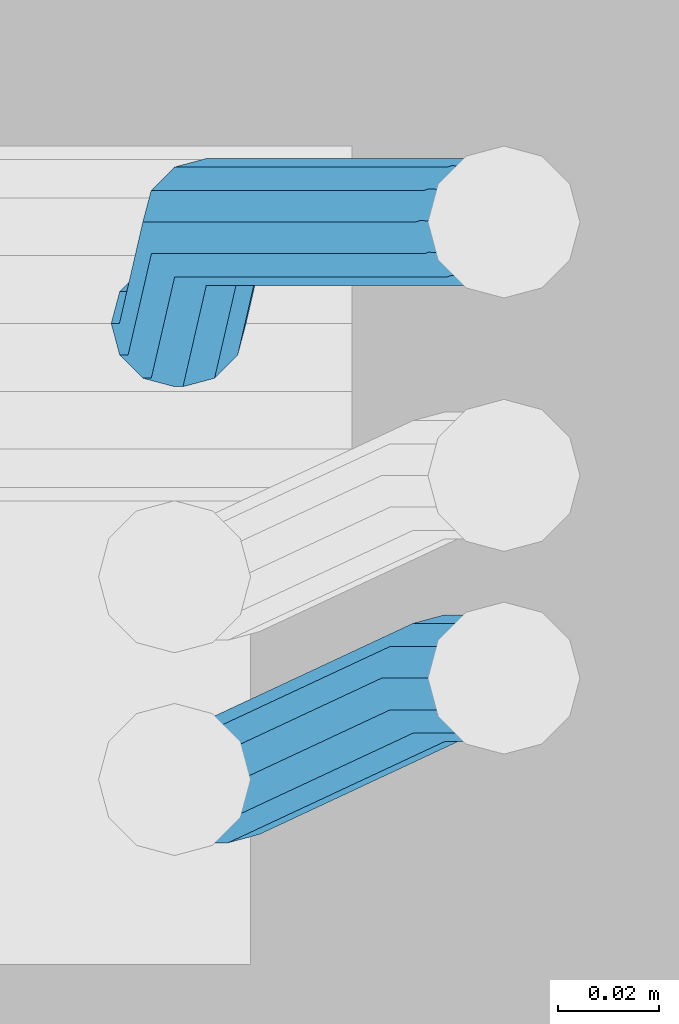
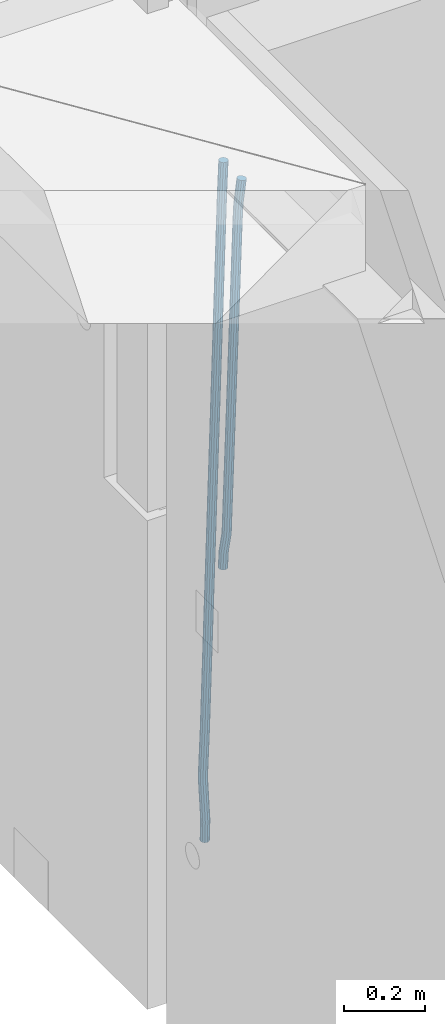
# One storey, part 122 of 350: 2 beams, 1 element without a shape of its own.
"""IFC2X3 building model written with IfcOpenShell, lengths in millimetres."""

from ifc_helpers import new_model, si_unit, frame, origin_with_axes, place, context, subcontext, project, spatial, faceted_brep, material, type_object, element, aggregate, save


model = new_model("IFC2X3")

# Units and contexts
model_context = context("Model", 3, precision=1e-05, world=origin_with_axes())
body_context = subcontext(model_context, "Body", "Model", "MODEL_VIEW")
ifc_project = project(units=[si_unit("LENGTHUNIT", "METRE", prefix="MILLI"), si_unit("AREAUNIT", "SQUARE_METRE"), si_unit("VOLUMEUNIT", "CUBIC_METRE"), si_unit("MASSUNIT", "GRAM", prefix="KILO"), si_unit("TIMEUNIT", "SECOND"), si_unit("PLANEANGLEUNIT", "RADIAN"), si_unit("SOLIDANGLEUNIT", "STERADIAN"), si_unit("THERMODYNAMICTEMPERATUREUNIT", "DEGREE_CELSIUS"), si_unit("LUMINOUSINTENSITYUNIT", "LUMEN")], contexts=[model_context])

# Site, building, storey
site_placement = place(None, origin_with_axes())
site = spatial("IfcSite", under=ifc_project, at=site_placement, CompositionType="ELEMENT")
building_placement = place(site_placement, origin_with_axes())
building = spatial("IfcBuilding", under=site, at=building_placement, CompositionType="ELEMENT")
storey_placement = place(building_placement, origin_with_axes())
storey = spatial("IfcBuildingStorey", under=building, at=storey_placement, Name="2", CompositionType="ELEMENT", Elevation=0.0)

# Assembly, beams
assembly_placement = place(storey_placement, origin_with_axes())
assembly = element("IfcElementAssembly", 1, at=assembly_placement, inside=storey, AssemblyPlace="NOTDEFINED", PredefinedType="REINFORCEMENT_UNIT")
ifc_material = material()
beam_type = type_object("IfcBeamType", Name="D25", PredefinedType="NOTDEFINED")
beam_1_placement = place(assembly_placement, frame((17644.9989431251, 20116.4982803956, 86267.5035525011), z_axis=(0.0, 1.0, 0.0), x_axis=(0.0467115440025518, 0.0, 0.998908420055061)))
beam_1 = element("IfcBeam", 2, at=beam_1_placement, type_object=beam_type, material=ifc_material, Name="JM25", ObjectType="D25", context=body_context, shape_type="Brep", body=[
    faceted_brep([(-7.41420080885291e-08, -12.5, -3.63797880709171e-12), (-6.42030499875546e-08, -10.8253175473074, -6.25000000000364), (48.7743672639481, -10.8253174221936, -6.25), (48.7743672682554, -12.4999998748863, 0.0), (-3.70782800018787e-08, -6.25000000000364, -10.8253175473074), (48.7743672522192, -6.24999987488263, -10.8253175473037), (-1.45519152283669e-11, -3.63797880709171e-12, -12.5), (48.7743672361976, 1.25113729154691e-07, -12.5), (3.70637280866504e-08, 6.25, -10.8253175473074), (48.7743672201614, 6.25000012511737, -10.8253175473037), (6.42030499875546e-08, 10.8253175473001, -6.25000000000364), (48.774367208418, 10.8253176724174, -6.25), (7.41420080885291e-08, 12.4999999999927, 0.0), (48.7743672041252, 12.5000001251174, 0.0), (6.42176019027829e-08, 10.8253175473001, 6.24999999999636), (48.774367208418, 10.8253176724174, 6.25), (3.70928319171071e-08, 6.24999999999636, 10.8253175473037), (48.7743672201614, 6.25000012511737, 10.8253175473037), (1.45519152283669e-11, -3.63797880709171e-12, 12.4999999999964), (48.7743672361976, 1.25113729154691e-07, 12.5), (-3.7049176171422e-08, -6.25000000000364, 10.8253175473001), (48.7743672522192, -6.24999987488263, 10.8253175473037), (-6.41884980723262e-08, -10.8253175473074, 6.25), (48.7743672639481, -10.8253174221936, 6.25), (50.6284132863948, -10.8253174174351, -6.25), (50.7256294211547, -12.4999998698804, 0.0), (50.362813866901, -6.2499998708081, -10.8253175473037), (49.9999983126327, 1.28262399812229e-07, -12.5), (49.6371827583935, 6.25000012732926, -10.8253175473037), (49.3715833388851, 10.8253176739527, -6.25), (49.2743672041252, 12.5000001264016, 0.0), (49.3715833388851, 10.8253176739527, 6.25), (49.6371827583935, 6.25000012732926, 10.8253175473037), (49.9999983126327, 1.28262399812229e-07, 12.5), (50.362813866901, -6.2499998708081, 10.8253175473037), (50.6284132863948, -10.8253174174351, 6.25), (52.4700055286376, -10.6107838149001, -6.25), (52.6637847850943, -12.2742172873113, 0.0), (51.9405907545442, -6.0661990532717, -10.8253175473037), (51.2173967239651, 0.141819180764287, -12.5), (50.494202693415, 6.34983741480755, -10.8253175473037), (49.9647879192926, 10.8944221764359, -6.25), (49.7710086628358, 12.5578556488472, 0.0), (49.9647879192926, 10.8944221764359, 6.25), (50.494202693415, 6.34983741480755, 10.8253175473037), (51.2173967239651, 0.141819180764287, 12.5), (51.9405907545442, -6.0661990532717, 10.8253175473037), (52.4700055286376, -10.6107838149037, 6.25), (100.1682419055, -5.05424733003747, -6.25), (100.362021161956, -6.71768080244692, 0.0), (99.6388271314063, -0.509662568409112, -10.8253175473037), (98.9156331008271, 5.69835566563052, -12.5), (98.192439070277, 11.9063738996665, -10.8253175473037), (97.6630242961546, 16.4509586612985, -6.25), (97.4692450396979, 18.1143921337098, 0.0), (97.6630242961546, 16.4509586612985, 6.25), (98.192439070277, 11.9063738996665, 10.8253175473037), (98.9156331008271, 5.69835566563052, 12.5), (99.6388271314063, -0.509662568409112, 10.8253175473037), (100.1682419055, -5.05424733003747, 6.25), (100.829389846811, -4.97722786481609, -6.25), (100.858662620667, -6.65982528000313, 0.0), (100.613505361369, -0.39611884945225, -10.8253175473037), (100.268855237926, 5.8559973049887, -12.5), (99.8877881987282, 12.1038711239344, -10.8253175473037), (99.5724108491268, 16.6733898631865, -6.25), (99.4072282953421, 18.3401546667665, 0.0), (99.4365010692127, 16.6575572515831, 6.25), (99.6523855546402, 12.0764482362174, 10.8253175473037), (99.9970356780832, 5.82433208178009, 12.5), (100.37810271731, -0.423541737165579, 10.8253175473037), (100.693480066882, -4.99306047642312, 6.25), (101.494850382805, -4.9772278650471, -6.23547852116099), (101.358543616545, -6.65982528017412, 0.0109082521194068), (101.594541309358, -0.396118849792401, -10.8039096771354), (101.63090429295, 5.85599730451395, -12.4702777768798), (101.594195901474, 12.1038711233377, -10.7880808337759), (101.49425211882, 16.6733898625134, -6.2080621602363), (101.357852800793, 18.340154666088, 0.0425659388420172), (101.221546034547, 16.6575572509591, 6.28895271212241), (101.121855107995, 12.0764482357044, 10.8573838680968), (101.085492124403, 5.82433208139992, 12.5237519678412), (101.122200515863, -0.423541737425694, 10.8415550247373), (101.222144298532, -4.99306047660866, 6.26153635119772), (1016.15234243186, -4.97722818425427, 13.7239010304511), (1016.01603566563, -6.65982559938311, 19.9702878037351), (1016.25203335841, -0.396119168995938, 9.15546987447669), (1016.28839634202, 5.85599698530859, 7.48910177473226), (1016.25168795056, 12.1038708041378, 9.17129871783618), (1016.15174416787, 16.6733895433135, 13.7513173913758), (1016.01534484986, 18.3401543468826, 20.0019454904541), (1015.8790380836, 16.6575569317556, 26.2483322637381), (1015.77934715705, 12.0764479165045, 30.8167634197125), (1015.74298417347, 5.82433176219456, 32.4831315194569), (1015.77969256493, -0.423542056632868, 30.8009345763494), (1015.8796363476, -4.99306079580856, 26.2209159028134), (1016.72024271244, -4.97722818445254, 13.7362935788587), (1016.65208128402, -6.65982559960139, 19.984167399125), (1016.77009392806, -0.396119169179656, 9.16677483576495), (1016.7882773379, 5.85599698513579, 7.50001002685531), (1016.76992071191, 12.1038708039559, 9.18260743664359), (1016.71994269331, 16.6733895431171, 13.7637164479929), (1016.65173485172, 18.3401543466607, 20.015832600875), (1016.58357342328, 16.65755693151, 26.2637064211413), (1016.53372220766, 12.0764479162353, 30.833225164235), (1016.51553879784, 5.82433176192717, 32.4999899731447), (1016.53389542381, -0.423542056894803, 30.8173925633564), (1016.58387344243, -4.99306079605594, 26.2362835520071), (1017.28827819017, -4.97722813975997, 13.7362935788587), (1017.28827832255, -6.6598255495519, 19.984167399125), (1017.28827782976, -0.396119128414284, 9.16677483576495), (1017.28827733788, 5.85599702447144, 7.50001002685531), (1017.28827684635, 12.103870844734, 9.18260743664359), (1017.28827648686, 16.6733895878278, 13.7637164479929), (1017.28827635571, 18.3401543967448, 20.015832600875), (1017.28827648809, 16.657556986951, 26.2637064211413), (1017.2882768485, 12.0764479756035, 30.833225164235), (1017.28827734038, 5.8243318227178, 32.4999899731447), (1017.28827783192, -0.423541997544817, 30.8173925633564), (1017.28827819142, -4.99306074063679, 26.2362835520071), (1065.6667756622, -4.97722433367016, 13.7362935788587), (1065.66677579457, -6.65982174345845, 19.984167399125), (1065.6667753018, -0.3961153223172, 9.16677483576495), (1065.66677480991, 5.85600083056488, 7.50001002685531), (1065.66677431838, 12.1038746508275, 9.18260743664359), (1065.66677395887, 16.6733933939249, 13.7637164479929), (1065.66677382775, 18.3401582028346, 20.015832600875), (1065.66677396011, 16.6575607930445, 26.2637064211413), (1065.66677432053, 12.0764517816933, 30.833225164235), (1065.6667748124, 5.82433562881488, 32.4999899731447), (1065.66677530395, -0.423538191451371, 30.8173925633564), (1065.66677566344, -4.99305693454517, 26.2362835520071), (1067.07165110651, -4.97722422314291, 13.7362935788587), (1067.13694763639, -6.65982162779255, 19.984167399125), (1066.89387208481, -0.396115225779795, 9.16677483576495), (1066.6512463166, 5.85600090801745, 7.50001002685531), (1066.40878518049, 12.1038747092061, 9.18260743664359), (1066.23145594214, 16.6733934383519, 13.7637164479929), (1066.16677382775, 18.340158242172, 20.015832600875), (1066.23207035761, 16.6575608375188, 26.2637064211413), (1066.40984937931, 12.0764518401556, 30.833225164235), (1066.65247514757, 5.82433570636204, 32.4999899731447), (1066.89493628364, -0.423538094826654, 30.8173925633564), (1067.07226552199, -4.99305682397062, 26.2362835520071), (1068.47230333716, -4.86837412698696, 13.736334784764), (1068.60269804588, -6.54588751704068, 19.9842150143704), (1068.11728165975, -0.301059828409052, 9.16679859123906), (1067.63276078545, 5.93224720081525, 7.50000996663584), (1067.14856769117, 12.161337376032, 9.18258357686864), (1066.79444152558, 16.7171310152116, 13.7636751818718), (1066.66527010873, 18.3789068918468, 20.0157849856296), (1066.79566481744, 16.7013935018003, 26.263665215236), (1067.15068649485, 12.134079203217, 30.8332014087609), (1067.63520736917, 5.90077217399266, 32.4999900333642), (1068.11940046342, -0.328318001224034, 30.8174164231314), (1068.47352662902, -4.88411164040008, 26.2363248181282), (1142.62319484423, 0.89544508106701, 13.736334784764), (1142.75358955294, -0.782068308983071, 19.9842150143704), (1142.26817316683, 5.4627593796431, 9.16679859123906), (1141.78365229251, 11.6960664088729, 7.50000996663584), (1141.29945919824, 17.9251565840896, 9.18258357686864), (1140.94533303265, 22.4809502232638, 13.7636751818718), (1140.81616161579, 24.1427260999008, 20.0157849856296), (1140.94655632452, 22.4652127098525, 26.263665215236), (1141.30157800192, 17.8978984112746, 30.8332014087609), (1141.78609887623, 11.6645913820466, 32.4999900333642), (1142.27029197049, 5.43550120682994, 30.8174164231314), (1142.6244181361, 0.879707567652076, 26.2363248181282)], [[[0, 1, 2, 3]], [[1, 4, 5, 2]], [[4, 6, 7, 5]], [[6, 8, 9, 7]], [[8, 10, 11, 9]], [[10, 12, 13, 11]], [[12, 14, 15, 13]], [[14, 16, 17, 15]], [[16, 18, 19, 17]], [[18, 20, 21, 19]], [[20, 22, 23, 21]], [[22, 0, 3, 23]], [[22, 20, 18, 16, 14, 12, 10, 8, 6, 4, 1, 0]], [[3, 2, 24, 25]], [[2, 5, 26, 24]], [[5, 7, 27, 26]], [[7, 9, 28, 27]], [[9, 11, 29, 28]], [[11, 13, 30, 29]], [[13, 15, 31, 30]], [[15, 17, 32, 31]], [[17, 19, 33, 32]], [[19, 21, 34, 33]], [[21, 23, 35, 34]], [[23, 3, 25, 35]], [[25, 24, 36, 37]], [[24, 26, 38, 36]], [[26, 27, 39, 38]], [[27, 28, 40, 39]], [[28, 29, 41, 40]], [[29, 30, 42, 41]], [[30, 31, 43, 42]], [[31, 32, 44, 43]], [[32, 33, 45, 44]], [[33, 34, 46, 45]], [[34, 35, 47, 46]], [[35, 25, 37, 47]], [[37, 36, 48, 49]], [[36, 38, 50, 48]], [[38, 39, 51, 50]], [[39, 40, 52, 51]], [[40, 41, 53, 52]], [[41, 42, 54, 53]], [[42, 43, 55, 54]], [[43, 44, 56, 55]], [[44, 45, 57, 56]], [[45, 46, 58, 57]], [[46, 47, 59, 58]], [[47, 37, 49, 59]], [[49, 48, 60, 61]], [[48, 50, 62, 60]], [[50, 51, 63, 62]], [[51, 52, 64, 63]], [[52, 53, 65, 64]], [[53, 54, 66, 65]], [[54, 55, 67, 66]], [[55, 56, 68, 67]], [[56, 57, 69, 68]], [[57, 58, 70, 69]], [[58, 59, 71, 70]], [[59, 49, 61, 71]], [[61, 60, 72, 73]], [[60, 62, 74, 72]], [[62, 63, 75, 74]], [[63, 64, 76, 75]], [[64, 65, 77, 76]], [[65, 66, 78, 77]], [[66, 67, 79, 78]], [[67, 68, 80, 79]], [[68, 69, 81, 80]], [[69, 70, 82, 81]], [[70, 71, 83, 82]], [[71, 61, 73, 83]], [[73, 72, 84, 85]], [[72, 74, 86, 84]], [[74, 75, 87, 86]], [[75, 76, 88, 87]], [[76, 77, 89, 88]], [[77, 78, 90, 89]], [[78, 79, 91, 90]], [[79, 80, 92, 91]], [[80, 81, 93, 92]], [[81, 82, 94, 93]], [[82, 83, 95, 94]], [[83, 73, 85, 95]], [[85, 84, 96, 97]], [[84, 86, 98, 96]], [[86, 87, 99, 98]], [[87, 88, 100, 99]], [[88, 89, 101, 100]], [[89, 90, 102, 101]], [[90, 91, 103, 102]], [[91, 92, 104, 103]], [[92, 93, 105, 104]], [[93, 94, 106, 105]], [[94, 95, 107, 106]], [[95, 85, 97, 107]], [[97, 96, 108, 109]], [[96, 98, 110, 108]], [[98, 99, 111, 110]], [[99, 100, 112, 111]], [[100, 101, 113, 112]], [[101, 102, 114, 113]], [[102, 103, 115, 114]], [[103, 104, 116, 115]], [[104, 105, 117, 116]], [[105, 106, 118, 117]], [[106, 107, 119, 118]], [[107, 97, 109, 119]], [[109, 108, 120, 121]], [[108, 110, 122, 120]], [[110, 111, 123, 122]], [[111, 112, 124, 123]], [[112, 113, 125, 124]], [[113, 114, 126, 125]], [[114, 115, 127, 126]], [[115, 116, 128, 127]], [[116, 117, 129, 128]], [[117, 118, 130, 129]], [[118, 119, 131, 130]], [[119, 109, 121, 131]], [[121, 120, 132, 133]], [[120, 122, 134, 132]], [[122, 123, 135, 134]], [[123, 124, 136, 135]], [[124, 125, 137, 136]], [[125, 126, 138, 137]], [[126, 127, 139, 138]], [[127, 128, 140, 139]], [[128, 129, 141, 140]], [[129, 130, 142, 141]], [[130, 131, 143, 142]], [[131, 121, 133, 143]], [[133, 132, 144, 145]], [[132, 134, 146, 144]], [[134, 135, 147, 146]], [[135, 136, 148, 147]], [[136, 137, 149, 148]], [[137, 138, 150, 149]], [[138, 139, 151, 150]], [[139, 140, 152, 151]], [[140, 141, 153, 152]], [[141, 142, 154, 153]], [[142, 143, 155, 154]], [[143, 133, 145, 155]], [[145, 144, 156, 157]], [[144, 146, 158, 156]], [[146, 147, 159, 158]], [[147, 148, 160, 159]], [[148, 149, 161, 160]], [[149, 150, 162, 161]], [[150, 151, 163, 162]], [[151, 152, 164, 163]], [[152, 153, 165, 164]], [[153, 154, 166, 165]], [[154, 155, 167, 166]], [[155, 145, 157, 167]], [[158, 159, 160, 161, 162, 163, 164, 165, 166, 167, 157, 156]]]),
])
beam_2_placement = place(assembly_placement, frame((17645.0, 20206.4982799665, 85390.0), z_axis=(0.999642804629538, 0.000205762999925497, -0.0267249099901003), x_axis=(0.0267249109941254, -4.30000210532798e-08, 0.999642825779465)))
beam_2 = element("IfcBeam", 3, at=beam_2_placement, type_object=beam_type, material=ifc_material, Name="JM25", ObjectType="D25", context=body_context, shape_type="Brep", body=[
    faceted_brep([(-7.41420080885291e-08, -12.5, -3.63797880709171e-12), (-6.42030499875546e-08, -10.8253175473074, -6.25000000000364), (59.4220778053423, -10.8253175324608, -6.25000005319089), (59.4220778086747, -12.4999999851534, -5.3194526117295e-08), (-3.70782800018787e-08, -6.25000000000364, -10.8253175473074), (59.4220778020681, -6.24999998515341, -10.8253176004946), (-1.45519152283669e-11, -3.63797880709171e-12, -12.5), (59.4220777997252, 1.48465915117413e-08, -12.5000000531927), (3.70637280866504e-08, 6.25, -10.8253175473074), (59.422077798954, 6.25000001485023, -10.8253176004982), (6.42030499875546e-08, 10.8253175473001, -6.25000000000364), (59.4220777999435, 10.8253175621539, -6.25000005319089), (7.41420080885291e-08, 12.4999999999927, 0.0), (59.4220778024173, 12.5000000148466, -5.31908881384879e-08), (6.42176019027829e-08, 10.8253175473001, 6.24999999999636), (59.4220778057497, 10.8253175621576, 6.24999994680911), (3.70928319171071e-08, 6.24999999999636, 10.8253175473037), (59.4220778090239, 6.25000001485023, 10.8253174941128), (1.45519152283669e-11, -3.63797880709171e-12, 12.4999999999964), (59.4220778113668, 1.48465915117413e-08, 12.4999999468128), (-3.7049176171422e-08, -6.25000000000364, 10.8253175473001), (59.4220778121526, -6.24999998515705, 10.8253174941183), (-6.41884980723262e-08, -10.8253175473074, 6.25), (59.422077811163, -10.8253175324571, 6.24999994680547), (60.1059015733626, -10.8253175322861, -6.25000005380571), (59.9220778086747, -12.4999999850261, -5.36383595317602e-08), (60.5270973313018, -6.24999998487692, -10.8253176014878), (61.0728060192778, 1.52613210957497e-08, -12.5000000546715), (61.5968054350378, 6.25000001539229, -10.8253176024446), (61.9586903583258, 10.825317562787, -6.25000005546281), (62.0614940161613, 12.5000000155051, -5.55555743630975e-08), (61.8776702514588, 10.8253175627651, 6.24999994460995), (61.4564744935342, 6.25000001535955, 10.8253174922938), (60.9107658055436, 1.52213033288717e-08, 12.4999999454776), (60.3867663897981, -6.2499999849133, 10.8253174932506), (60.0248814664956, -10.825317532308, 6.24999994626887), (60.7797257564671, -10.9415004936782, -6.24120031120765), (60.4147662867617, -12.5849509379113, 0.00643416450657242), (61.6159581115353, -6.43774490879878, -10.8110977280703), (62.6993955677171, -0.280461855141766, -12.4787577637399), (63.739731933616, 5.88050964549984, -10.7973322583985), (64.4582099200925, 10.3943422549237, -6.21735781835014), (64.6623139309086, 12.0515581706859, 0.03396510384664), (64.2973544612178, 10.4081077264564, 6.28159957956086), (63.461122106135, 5.90435214157333, 10.8514969964235), (62.3776846499532, -0.252930912083684, 12.5191570320894), (61.3373482840689, -6.41390241272165, 10.8377315267553), (60.6188702975924, -10.9277350221564, 6.25775708670699), (173.678050556482, -30.407797550004, -4.76681541592006), (173.313091086762, -32.0512479942336, 1.4808190597978), (174.514282911536, -25.9040419651246, -9.33671283278272), (175.597720367718, -19.7467589114676, -11.0043728684504), (176.638056733602, -13.585787410826, -9.32294736311087), (177.356534720093, -9.0719548013949, -4.74297292306073), (177.560638730924, -7.41473888563996, 1.50834999913423), (177.195679261218, -9.05818932986585, 7.75598447485027), (176.35944690615, -13.5619449147489, 12.3258818917166), (175.276009449968, -19.7192279684059, 13.9935419273806), (174.235673084069, -25.8801994690475, 12.3121164220465), (173.517195097593, -30.3940320784823, 7.73214198199094), (176.138237106381, -30.8319909317906, -4.73468684452382), (175.913853754129, -32.499679968274, 1.51478347157899), (176.589132212815, -26.2617942428296, -9.30961653639861), (177.145722093832, -20.0136704134529, -10.98415688768), (177.658868940271, -13.7617991779516, -9.30961616354944), (177.991075469021, -9.18136438506554, -4.73468619872801), (178.053327209011, -7.49968983852159, 1.5147842172828), (177.828943856759, -9.16737887500858, 7.76425453338925), (177.37804875031, -13.7375755639696, 12.3391842252604), (176.821458869294, -19.9856993933463, 14.0137245765418), (176.308312022869, -26.237570628844, 12.3391838524112), (175.976105494119, -30.8180054217337, 7.76425388758798), (178.634722048839, -30.8318743800774, -4.70223538057326), (178.552989161486, -32.4996730848652, 1.54907076560085), (178.694593853957, -26.2615981169292, -9.28219734144659), (178.71656197503, -20.0134461293128, -10.9636180082289), (178.694740071747, -13.7616056964944, -9.29596207112627), (178.634975305482, -9.18125241366579, -4.72607659172718), (178.553281597095, -7.49968824400275, 1.52154130624513), (178.471548709742, -9.16748694879061, 7.7728474524265), (178.411676904623, -13.7377632119424, 12.3528094132944), (178.389708783536, -19.9859151995588, 14.0342300800785), (178.411530686833, -26.23775563237, 12.3665741429741), (178.471295453099, -30.8181089152022, 7.79668866358043), (319.488626215083, -30.8314939674237, -2.86053540860667), (319.406893327759, -32.499292672208, 3.39077073757289), (319.548498020216, -26.261217704272, -7.44049736947818), (319.570466141289, -20.0130657166519, -9.12191803626411), (319.548644237992, -13.7612252838408, -7.45426209915786), (319.488879471741, -9.18087200101581, -2.88437661976423), (319.407185763353, -7.4993078313455, 3.36324127821172), (319.325452876015, -9.167106536137, 9.61454742438946), (319.265581070882, -13.7373827992851, 14.1945093852592), (319.243612949809, -19.9855347868979, 15.8759300520433), (319.265434853078, -26.2373752197163, 14.2082741149388), (319.325199619343, -30.8177285025449, 9.63838863554338), (320.017443228702, -30.8314925392151, -2.85362099409576), (319.964532372032, -32.4992911661575, 3.39806200733256), (320.056202037245, -26.2612163330814, -7.43385901266629), (320.070423406214, -20.013064366387, -9.11538097016819), (320.056296731302, -13.7612239127957, -7.44762441603234), (320.01760724363, -9.18087057304729, -2.87746337211138), (319.964721760145, -7.4993063255788, 3.37053120060227), (319.91181090349, -9.16710495252482, 9.62221420203059), (319.873052094961, -13.7373811586476, 14.2024522205975), (319.858830725978, -19.9855331253457, 15.8839741781048), (319.87295740089, -26.2373735789442, 14.2162176239653), (319.911646888577, -30.8177269186926, 9.64605658004257), (320.546301518712, -30.8314921215424, -2.85158332608989), (320.522214942423, -32.4992907257256, 3.40021073403295), (320.563945682734, -26.2612159320888, -7.431902698474), (320.570419694937, -20.0130639715098, -9.1134545062032), (320.563988849026, -13.7612235118395, -7.44566830037184), (320.546376284925, -9.1808701554437, -2.87542604797454), (320.522301275021, -7.49930588522329, 3.37267953023547), (320.498214698731, -9.16710448940648, 9.62447359036014), (320.480570534695, -13.7373806788601, 14.2047929627461), (320.474096522506, -19.9855326394354, 15.8863447704753), (320.480527368418, -26.2373730991094, 14.2185585646439), (320.498139932504, -30.8177264555052, 9.64831631225024), (1894.35323904471, -30.8302491939103, 3.21222639639745), (1894.32915246842, -32.4980477980898, 9.46402045652394), (1894.37088320871, -26.2599730044531, -1.36809297598302), (1894.37735722095, -20.0118210438777, -3.04964478371585), (1894.37092637502, -13.7599805842037, -1.38185857788449), (1894.35331381093, -9.1796272278043, 3.18838367451281), (1894.32923880102, -7.4980629575839, 9.43648925272464), (1894.30515222471, -9.16586156176709, 15.6882833128511), (1894.2875080607, -13.7361377512207, 20.2686026852371), (1894.28103404849, -19.9842897117996, 21.9501544929644), (1894.2874648944, -26.2361301714736, 20.2823682871331), (1894.30507745848, -30.8164835278658, 15.7121260347358), (1894.91223858956, -30.8302487524343, 3.21438019734705), (1894.84772318714, -32.4980473885444, 9.46601848696628), (1894.98133310449, -26.2599725223481, -1.36574093906893), (1895.03649291246, -20.0118205233157, -3.04710516254454), (1895.06293798747, -13.7599800376811, -1.37919228721876), (1895.05358239301, -9.17962667476604, 3.19108177892304), (1895.01093295308, -7.49806241920669, 9.43911579066662), (1894.94641755069, -9.16586105532406, 15.6907540802767), (1894.87732303573, -13.7361372854102, 20.2708752166945), (1894.82216322777, -19.984289284439, 21.9522394401702), (1894.79571815276, -26.2361297700772, 20.284326564848), (1894.80507374721, -30.8164831329887, 15.7140524987026), (1895.47114527243, -30.837537004496, 3.22181869265842), (1895.36620776, -32.5048085284143, 9.47291900396158), (1895.59168159126, -26.267931585553, -1.35761780421126), (1895.69551910722, -20.0204143533228, -3.03833417552232), (1895.75483464175, -13.7690025048832, -1.36998382688762), (1895.75373464527, -9.18875679657504, 3.20040011310266), (1895.69251386097, -7.50695036707475, 9.44818695861068), (1895.58757634854, -9.17422189099307, 15.699287269912), (1895.4670400297, -13.7438273099324, 20.2787237667835), (1895.36320251375, -19.9913445421626, 21.9594401380946), (1895.30388697921, -26.2427563905985, 20.2910897894599), (1895.30498697569, -30.823002098914, 15.720705849466), (1917.25744196717, -31.1216345590001, 3.51177275974987), (1917.15250445475, -32.788906082922, 9.7628730710494), (1917.37797828601, -26.5520291400608, -1.0676637371198), (1917.48181580196, -20.3045119078306, -2.7483801084345), (1917.5411313365, -14.0531000593946, -1.08002975979252), (1917.54003134, -9.47285435107915, 3.49035418019412), (1917.47881055571, -7.7910479215825, 9.73814102570577), (1917.37387304328, -9.45831944550082, 15.9892413370071), (1917.25333672446, -14.0279248644365, 20.5686778338786), (1917.14949920849, -20.2754420966667, 22.2493942051933), (1917.09018367396, -26.5268539451099, 20.5810438565477), (1917.09128367042, -31.1070996534218, 16.0106599165647), (1917.94316974688, -31.1305765828838, 3.52089911846269), (1917.85264237775, -32.7980360178735, 9.77219121452072), (1918.02633208608, -26.5604837999635, -1.05903478912296), (1918.0798461137, -20.3123103396429, -2.7404209163069), (1918.08937278928, -14.0602492347753, -1.07273320814602), (1918.05235944779, -9.47953520944429, 3.49717276072806), (1917.9787237842, -7.79756688750422, 9.74479437647096), (1917.88819641506, -9.46502632249758, 15.9960864725308), (1917.80503407588, -14.0351191054142, 20.5760203801128), (1917.75152004823, -20.2832925657385, 22.257406507304), (1917.74199337266, -26.5353536706025, 20.5897187991395), (1917.77900671415, -31.1160676959298, 16.0198128302654), (1918.62895550129, -31.1285475281402, 3.52982218347461), (1918.55283939735, -32.795947999115, 9.78130547352521), (1918.67474087057, -26.5585779185749, -1.05060823136955), (1918.67792735249, -20.3105588367471, -2.73266314035027), (1918.63766113177, -14.0586419499232, -1.06563728897891), (1918.56473150974, -9.47802333907384, 3.50379109209644), (1918.47867991975, -7.79607606181162, 9.75124735830832), (1918.40256381579, -9.46347653279008, 16.0027306483644), (1918.35677844651, -14.0334461423481, 20.5831610632049), (1918.35359196461, -20.2814652241759, 22.2652159721838), (1918.39385818531, -26.5333821109998, 20.5981901208143), (1918.46678780734, -31.1140007218564, 16.0287617397316), (2018.62971518922, -30.8303462840922, 4.82693655916046), (2018.5535990853, -32.4977467550671, 11.0784198492183), (2018.67550055851, -26.2603766745233, 0.246506144323575), (2018.67868704045, -20.0123575926991, -1.43554876465714), (2018.63842081973, -13.7604407058789, 0.231477086710584), (2018.5654911977, -9.17982209502588, 4.80090546778956), (2018.47943960771, -7.49787481776366, 11.0483617339996), (2018.40332350375, -9.16527528874212, 17.2998450240593), (2018.35753813446, -13.7352448983038, 21.880275438898), (2018.35435165254, -19.9832639801316, 23.5623303478787), (2018.39461787326, -26.2351808669555, 21.8953044965092), (2018.46754749528, -30.8157994778048, 17.3258761154248)], [[[0, 1, 2, 3]], [[1, 4, 5, 2]], [[4, 6, 7, 5]], [[6, 8, 9, 7]], [[8, 10, 11, 9]], [[10, 12, 13, 11]], [[12, 14, 15, 13]], [[14, 16, 17, 15]], [[16, 18, 19, 17]], [[18, 20, 21, 19]], [[20, 22, 23, 21]], [[22, 0, 3, 23]], [[22, 20, 18, 16, 14, 12, 10, 8, 6, 4, 1, 0]], [[3, 2, 24, 25]], [[2, 5, 26, 24]], [[5, 7, 27, 26]], [[7, 9, 28, 27]], [[9, 11, 29, 28]], [[11, 13, 30, 29]], [[13, 15, 31, 30]], [[15, 17, 32, 31]], [[17, 19, 33, 32]], [[19, 21, 34, 33]], [[21, 23, 35, 34]], [[23, 3, 25, 35]], [[25, 24, 36, 37]], [[24, 26, 38, 36]], [[26, 27, 39, 38]], [[27, 28, 40, 39]], [[28, 29, 41, 40]], [[29, 30, 42, 41]], [[30, 31, 43, 42]], [[31, 32, 44, 43]], [[32, 33, 45, 44]], [[33, 34, 46, 45]], [[34, 35, 47, 46]], [[35, 25, 37, 47]], [[37, 36, 48, 49]], [[36, 38, 50, 48]], [[38, 39, 51, 50]], [[39, 40, 52, 51]], [[40, 41, 53, 52]], [[41, 42, 54, 53]], [[42, 43, 55, 54]], [[43, 44, 56, 55]], [[44, 45, 57, 56]], [[45, 46, 58, 57]], [[46, 47, 59, 58]], [[47, 37, 49, 59]], [[49, 48, 60, 61]], [[48, 50, 62, 60]], [[50, 51, 63, 62]], [[51, 52, 64, 63]], [[52, 53, 65, 64]], [[53, 54, 66, 65]], [[54, 55, 67, 66]], [[55, 56, 68, 67]], [[56, 57, 69, 68]], [[57, 58, 70, 69]], [[58, 59, 71, 70]], [[59, 49, 61, 71]], [[61, 60, 72, 73]], [[60, 62, 74, 72]], [[62, 63, 75, 74]], [[63, 64, 76, 75]], [[64, 65, 77, 76]], [[65, 66, 78, 77]], [[66, 67, 79, 78]], [[67, 68, 80, 79]], [[68, 69, 81, 80]], [[69, 70, 82, 81]], [[70, 71, 83, 82]], [[71, 61, 73, 83]], [[73, 72, 84, 85]], [[72, 74, 86, 84]], [[74, 75, 87, 86]], [[75, 76, 88, 87]], [[76, 77, 89, 88]], [[77, 78, 90, 89]], [[78, 79, 91, 90]], [[79, 80, 92, 91]], [[80, 81, 93, 92]], [[81, 82, 94, 93]], [[82, 83, 95, 94]], [[83, 73, 85, 95]], [[85, 84, 96, 97]], [[84, 86, 98, 96]], [[86, 87, 99, 98]], [[87, 88, 100, 99]], [[88, 89, 101, 100]], [[89, 90, 102, 101]], [[90, 91, 103, 102]], [[91, 92, 104, 103]], [[92, 93, 105, 104]], [[93, 94, 106, 105]], [[94, 95, 107, 106]], [[95, 85, 97, 107]], [[97, 96, 108, 109]], [[96, 98, 110, 108]], [[98, 99, 111, 110]], [[99, 100, 112, 111]], [[100, 101, 113, 112]], [[101, 102, 114, 113]], [[102, 103, 115, 114]], [[103, 104, 116, 115]], [[104, 105, 117, 116]], [[105, 106, 118, 117]], [[106, 107, 119, 118]], [[107, 97, 109, 119]], [[109, 108, 120, 121]], [[108, 110, 122, 120]], [[110, 111, 123, 122]], [[111, 112, 124, 123]], [[112, 113, 125, 124]], [[113, 114, 126, 125]], [[114, 115, 127, 126]], [[115, 116, 128, 127]], [[116, 117, 129, 128]], [[117, 118, 130, 129]], [[118, 119, 131, 130]], [[119, 109, 121, 131]], [[121, 120, 132, 133]], [[120, 122, 134, 132]], [[122, 123, 135, 134]], [[123, 124, 136, 135]], [[124, 125, 137, 136]], [[125, 126, 138, 137]], [[126, 127, 139, 138]], [[127, 128, 140, 139]], [[128, 129, 141, 140]], [[129, 130, 142, 141]], [[130, 131, 143, 142]], [[131, 121, 133, 143]], [[133, 132, 144, 145]], [[132, 134, 146, 144]], [[134, 135, 147, 146]], [[135, 136, 148, 147]], [[136, 137, 149, 148]], [[137, 138, 150, 149]], [[138, 139, 151, 150]], [[139, 140, 152, 151]], [[140, 141, 153, 152]], [[141, 142, 154, 153]], [[142, 143, 155, 154]], [[143, 133, 145, 155]], [[145, 144, 156, 157]], [[144, 146, 158, 156]], [[146, 147, 159, 158]], [[147, 148, 160, 159]], [[148, 149, 161, 160]], [[149, 150, 162, 161]], [[150, 151, 163, 162]], [[151, 152, 164, 163]], [[152, 153, 165, 164]], [[153, 154, 166, 165]], [[154, 155, 167, 166]], [[155, 145, 157, 167]], [[157, 156, 168, 169]], [[156, 158, 170, 168]], [[158, 159, 171, 170]], [[159, 160, 172, 171]], [[160, 161, 173, 172]], [[161, 162, 174, 173]], [[162, 163, 175, 174]], [[163, 164, 176, 175]], [[164, 165, 177, 176]], [[165, 166, 178, 177]], [[166, 167, 179, 178]], [[167, 157, 169, 179]], [[169, 168, 180, 181]], [[168, 170, 182, 180]], [[170, 171, 183, 182]], [[171, 172, 184, 183]], [[172, 173, 185, 184]], [[173, 174, 186, 185]], [[174, 175, 187, 186]], [[175, 176, 188, 187]], [[176, 177, 189, 188]], [[177, 178, 190, 189]], [[178, 179, 191, 190]], [[179, 169, 181, 191]], [[181, 180, 192, 193]], [[180, 182, 194, 192]], [[182, 183, 195, 194]], [[183, 184, 196, 195]], [[184, 185, 197, 196]], [[185, 186, 198, 197]], [[186, 187, 199, 198]], [[187, 188, 200, 199]], [[188, 189, 201, 200]], [[189, 190, 202, 201]], [[190, 191, 203, 202]], [[191, 181, 193, 203]], [[194, 195, 196, 197, 198, 199, 200, 201, 202, 203, 193, 192]]]),
])
aggregate(assembly, [beam_1, beam_2])

save(model, "model.ifc")
